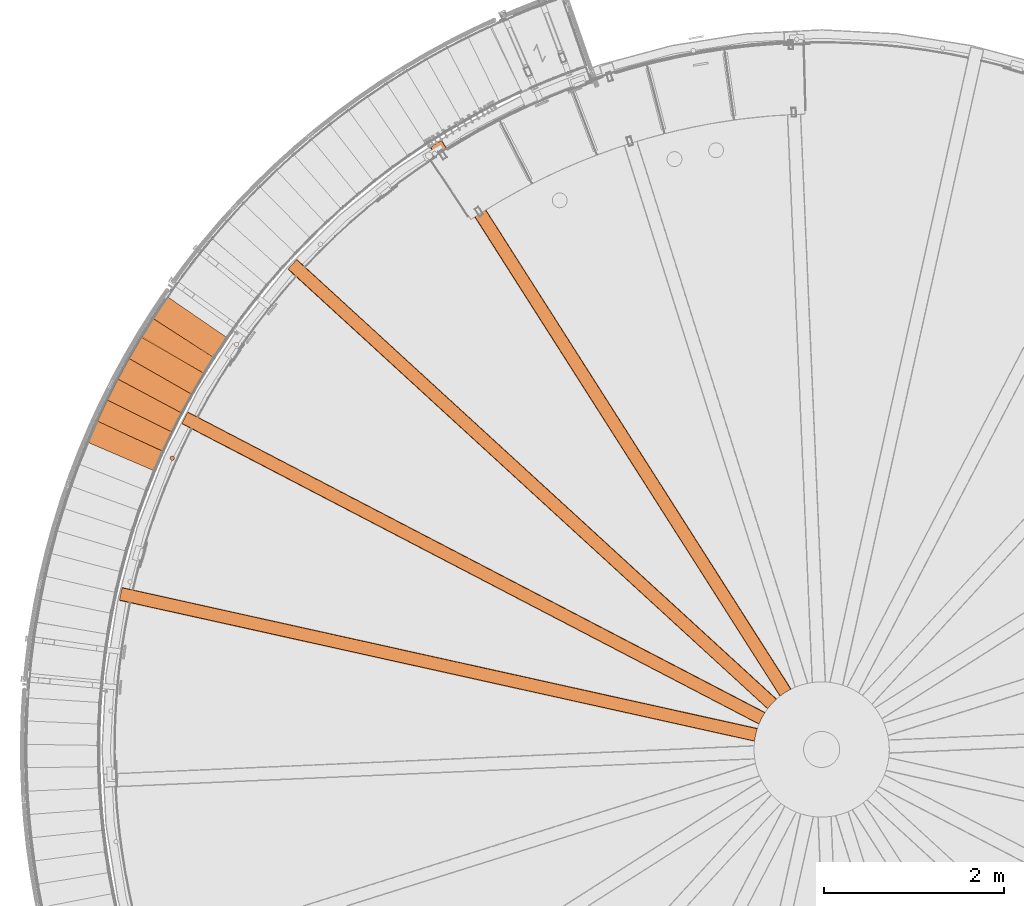
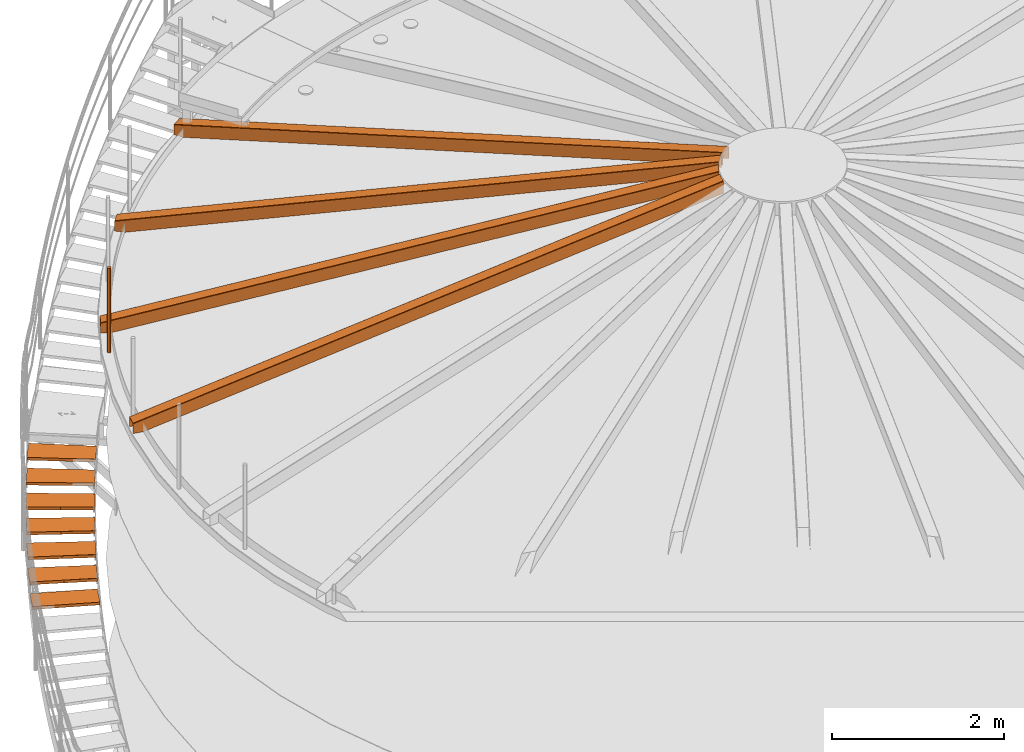
# One storey, part 29 of 126: 16 proxies.
"""IFC2X3 building model written with IfcOpenShell, lengths in millimetres."""

from ifc_helpers import new_model, si_unit, origin, origin_with_axes, place, context, project, spatial, faceted_brep, material, element, save


model = new_model("IFC2X3")

# Units and contexts
context_of_model_1 = context(None, 3, precision=0.1, world=origin())
context_of_model_2 = context(None, 3, precision=0.1, world=origin())
ifc_project = project(units=[si_unit("LENGTHUNIT", "METRE", prefix="MILLI"), si_unit("AREAUNIT", "SQUARE_METRE", prefix="CENTI"), si_unit("VOLUMEUNIT", "CUBIC_METRE", prefix="CENTI"), si_unit("MASSUNIT", "GRAM", prefix="KILO")], contexts=[context_of_model_1, context_of_model_2])

# Site, building, storey
site_placement = place(None, origin_with_axes())
site = spatial("IfcSite", under=ifc_project, at=site_placement, CompositionType="ELEMENT")
building_placement = place(site_placement, origin_with_axes())
building = spatial("IfcBuilding", under=site, at=building_placement, CompositionType="ELEMENT")
storey_placement = place(building_placement, origin_with_axes())
storey = spatial("IfcBuildingStorey", under=building, at=storey_placement, CompositionType="ELEMENT")

# Proxies
ifc_material_1 = material(Name="HOLZ")
proxy_1_placement = place(storey_placement, origin_with_axes())
element("IfcBuildingElementProxy", 1, at=proxy_1_placement, inside=storey, material=ifc_material_1, context=context_of_model_2, shape_type="Brep", body=[
    faceted_brep([(97.3821, 11904.88, 7274.6625), (85.7743, 11881.255, 7274.6625), (74.2371, 11857.595, 7274.6625), (62.7705, 11833.9, 7274.6625), (51.3748, 11810.172, 7274.6625), (40.05, 11786.41, 7274.6625), (28.7961, 11762.613, 7274.6625), (17.6134, 11738.784, 7274.6625), (6.5018, 11714.921, 7274.6625), (-4.5384, 11691.025, 7274.6625), (-15.5073, 11667.096, 7274.6625), (-26.4047, 11643.135, 7274.6625), (702.3153, 11313.033, 7274.6625), (713.3315, 11337.245, 7274.6625), (724.428, 11361.42, 7274.6625), (735.6046, 11385.559, 7274.6625), (746.8612, 11409.66, 7274.6625), (758.1978, 11433.724, 7274.6625), (769.6141, 11457.749, 7274.6625), (781.1101, 11481.737, 7274.6625), (792.6857, 11505.687, 7274.6625), (804.3406, 11529.598, 7274.6625), (816.0748, 11553.47, 7274.6625), (97.3821, 11904.88, 7234.6625), (816.0748, 11553.47, 7234.6625), (804.3406, 11529.598, 7234.6625), (792.6857, 11505.687, 7234.6625), (781.1101, 11481.737, 7234.6625), (769.6141, 11457.749, 7234.6625), (758.1978, 11433.724, 7234.6625), (746.8612, 11409.66, 7234.6625), (735.6046, 11385.559, 7234.6625), (724.428, 11361.42, 7234.6625), (713.3315, 11337.245, 7234.6625), (702.3153, 11313.033, 7234.6625), (-26.4047, 11643.135, 7234.6625), (-15.5073, 11667.096, 7234.6625), (-4.5384, 11691.025, 7234.6625), (6.5018, 11714.921, 7234.6625), (17.6134, 11738.784, 7234.6625), (28.7961, 11762.613, 7234.6625), (40.05, 11786.41, 7234.6625), (51.3748, 11810.172, 7234.6625), (62.7705, 11833.9, 7234.6625), (74.2371, 11857.595, 7234.6625), (85.7743, 11881.255, 7234.6625)], [[[0, 1, 2, 3, 4, 5, 6, 7, 8, 9, 10, 11, 12, 13, 14, 15, 16, 17, 18, 19, 20, 21, 22]], [[23, 24, 25, 26, 27, 28, 29, 30, 31, 32, 33, 34, 35, 36, 37, 38, 39, 40, 41, 42, 43, 44, 45]], [[0, 23, 45, 1]], [[1, 45, 44, 2]], [[2, 44, 43, 3]], [[3, 43, 42, 4]], [[4, 42, 41, 5]], [[5, 41, 40, 6]], [[6, 40, 39, 7]], [[7, 39, 38, 8]], [[8, 38, 37, 9]], [[9, 37, 36, 10]], [[10, 36, 35, 11]], [[11, 35, 34, 12]], [[12, 34, 33, 13]], [[13, 33, 32, 14]], [[14, 32, 31, 15]], [[15, 31, 30, 16]], [[16, 30, 29, 17]], [[17, 29, 28, 18]], [[18, 28, 27, 19]], [[19, 27, 26, 20]], [[20, 26, 25, 21]], [[21, 25, 24, 22]], [[22, 24, 23, 0]]]),
])
proxy_2_placement = place(storey_placement, origin_with_axes())
element("IfcBuildingElementProxy", 2, at=proxy_2_placement, inside=storey, material=ifc_material_1, context=context_of_model_2, shape_type="Brep", body=[
    faceted_brep([(215.5957, 12135.94, 7447.8688), (203.2975, 12112.667, 7447.8688), (191.0689, 12089.357, 7447.8688), (178.91, 12066.01, 7447.8688), (166.8207, 12042.627, 7447.8688), (154.8014, 12019.208, 7447.8688), (142.852, 11995.754, 7447.8688), (130.9727, 11972.264, 7447.8688), (119.1636, 11948.738, 7447.8688), (107.4248, 11925.178, 7447.8688), (95.7564, 11901.582, 7447.8688), (84.1584, 11877.952, 7447.8688), (802.8466, 11526.544, 7447.8688), (814.5707, 11550.422, 7447.8688), (826.3739, 11574.26, 7447.8688), (838.2562, 11598.059, 7447.8688), (850.2173, 11621.818, 7447.8688), (862.2573, 11645.538, 7447.8688), (874.3758, 11669.217, 7447.8688), (886.5729, 11692.856, 7447.8688), (898.8483, 11716.455, 7447.8688), (911.202, 11740.012, 7447.8688), (923.6337, 11763.529, 7447.8688), (215.5957, 12135.94, 7407.8688), (923.6337, 11763.529, 7407.8688), (911.202, 11740.012, 7407.8688), (898.8483, 11716.455, 7407.8688), (886.5729, 11692.856, 7407.8688), (874.3758, 11669.217, 7407.8688), (862.2573, 11645.538, 7407.8688), (850.2173, 11621.818, 7407.8688), (838.2562, 11598.059, 7407.8688), (826.3739, 11574.26, 7407.8688), (814.5707, 11550.422, 7407.8688), (802.8466, 11526.544, 7407.8688), (84.1584, 11877.952, 7407.8688), (95.7564, 11901.582, 7407.8688), (107.4248, 11925.178, 7407.8688), (119.1636, 11948.738, 7407.8688), (130.9727, 11972.264, 7407.8688), (142.852, 11995.754, 7407.8688), (154.8014, 12019.208, 7407.8688), (166.8207, 12042.627, 7407.8688), (178.91, 12066.01, 7407.8688), (191.0689, 12089.357, 7407.8688), (203.2975, 12112.667, 7407.8688)], [[[0, 1, 2, 3, 4, 5, 6, 7, 8, 9, 10, 11, 12, 13, 14, 15, 16, 17, 18, 19, 20, 21, 22]], [[23, 24, 25, 26, 27, 28, 29, 30, 31, 32, 33, 34, 35, 36, 37, 38, 39, 40, 41, 42, 43, 44, 45]], [[0, 23, 45, 1]], [[1, 45, 44, 2]], [[2, 44, 43, 3]], [[3, 43, 42, 4]], [[4, 42, 41, 5]], [[5, 41, 40, 6]], [[6, 40, 39, 7]], [[7, 39, 38, 8]], [[8, 38, 37, 9]], [[9, 37, 36, 10]], [[10, 36, 35, 11]], [[11, 35, 34, 12]], [[12, 34, 33, 13]], [[13, 33, 32, 14]], [[14, 32, 31, 15]], [[15, 31, 30, 16]], [[16, 30, 29, 17]], [[17, 29, 28, 18]], [[18, 28, 27, 19]], [[19, 27, 26, 20]], [[20, 26, 25, 21]], [[21, 25, 24, 22]], [[22, 24, 23, 0]]]),
])
proxy_3_placement = place(storey_placement, origin_with_axes())
element("IfcBuildingElementProxy", 3, at=proxy_3_placement, inside=storey, material=ifc_material_1, context=context_of_model_2, shape_type="Brep", body=[
    faceted_brep([(340.559, 12363.421, 7621.075), (327.5811, 12340.519, 7621.075), (314.6717, 12317.579, 7621.075), (301.8309, 12294.601, 7621.075), (289.0586, 12271.584, 7621.075), (276.3552, 12248.529, 7621.075), (263.7207, 12225.436, 7621.075), (251.1551, 12202.306, 7621.075), (238.6587, 12179.138, 7621.075), (226.2315, 12155.933, 7621.075), (213.8736, 12132.692, 7621.075), (201.5852, 12109.413, 7621.075), (909.6188, 11737.004, 7621.075), (922.0405, 11760.526, 7621.075), (934.5403, 11784.006, 7621.075), (947.1179, 11807.445, 7621.075), (959.7732, 11830.842, 7621.075), (972.5061, 11854.197, 7621.075), (985.3164, 11877.509, 7621.075), (998.2039, 11900.779, 7621.075), (1011.1686, 11924.006, 7621.075), (1024.2103, 11947.19, 7621.075), (1037.3289, 11970.331, 7621.075), (340.559, 12363.421, 7581.075), (1037.3289, 11970.331, 7581.075), (1024.2103, 11947.19, 7581.075), (1011.1686, 11924.006, 7581.075), (998.2039, 11900.779, 7581.075), (985.3164, 11877.509, 7581.075), (972.5061, 11854.197, 7581.075), (959.7732, 11830.842, 7581.075), (947.1179, 11807.445, 7581.075), (934.5403, 11784.006, 7581.075), (922.0405, 11760.526, 7581.075), (909.6188, 11737.004, 7581.075), (201.5852, 12109.413, 7581.075), (213.8736, 12132.692, 7581.075), (226.2315, 12155.933, 7581.075), (238.6587, 12179.138, 7581.075), (251.1551, 12202.306, 7581.075), (263.7207, 12225.436, 7581.075), (276.3552, 12248.529, 7581.075), (289.0586, 12271.584, 7581.075), (301.8309, 12294.601, 7581.075), (314.6717, 12317.579, 7581.075), (327.5811, 12340.519, 7581.075)], [[[0, 1, 2, 3, 4, 5, 6, 7, 8, 9, 10, 11, 12, 13, 14, 15, 16, 17, 18, 19, 20, 21, 22]], [[23, 24, 25, 26, 27, 28, 29, 30, 31, 32, 33, 34, 35, 36, 37, 38, 39, 40, 41, 42, 43, 44, 45]], [[0, 23, 45, 1]], [[1, 45, 44, 2]], [[2, 44, 43, 3]], [[3, 43, 42, 4]], [[4, 42, 41, 5]], [[5, 41, 40, 6]], [[6, 40, 39, 7]], [[7, 39, 38, 8]], [[8, 38, 37, 9]], [[9, 37, 36, 10]], [[10, 36, 35, 11]], [[11, 35, 34, 12]], [[12, 34, 33, 13]], [[13, 33, 32, 14]], [[14, 32, 31, 15]], [[15, 31, 30, 16]], [[16, 30, 29, 17]], [[17, 29, 28, 18]], [[18, 28, 27, 19]], [[19, 27, 26, 20]], [[20, 26, 25, 21]], [[21, 25, 24, 22]], [[22, 24, 23, 0]]]),
])
proxy_4_placement = place(storey_placement, origin_with_axes())
element("IfcBuildingElementProxy", 4, at=proxy_4_placement, inside=storey, material=ifc_material_1, context=context_of_model_2, shape_type="Brep", body=[
    faceted_brep([(472.1637, 12587.125, 7794.2813), (458.5174, 12564.615, 7794.2813), (444.9384, 12542.065, 7794.2813), (431.4267, 12519.474, 7794.2813), (417.9826, 12496.843, 7794.2813), (404.6061, 12474.172, 7794.2813), (391.2973, 12451.461, 7794.2813), (378.0564, 12428.711, 7794.2813), (364.8835, 12405.921, 7794.2813), (351.7787, 12383.092, 7794.2813), (338.742, 12360.224, 7794.2813), (325.7738, 12337.317, 7794.2813), (1022.5392, 11944.23, 7794.2813), (1035.648, 11967.376, 7794.2813), (1048.8334, 11990.478, 7794.2813), (1062.0955, 12013.537, 7794.2813), (1075.434, 12036.551, 7794.2813), (1088.8487, 12059.521, 7794.2813), (1102.3396, 12082.446, 7794.2813), (1115.9065, 12105.327, 7794.2813), (1129.5493, 12128.162, 7794.2813), (1143.2677, 12150.952, 7794.2813), (1157.0617, 12173.696, 7794.2813), (472.1637, 12587.125, 7754.2813), (1157.0617, 12173.696, 7754.2813), (1143.2677, 12150.952, 7754.2813), (1129.5493, 12128.162, 7754.2813), (1115.9065, 12105.327, 7754.2813), (1102.3396, 12082.446, 7754.2813), (1088.8487, 12059.521, 7754.2813), (1075.434, 12036.551, 7754.2813), (1062.0955, 12013.537, 7754.2813), (1048.8334, 11990.478, 7754.2813), (1035.648, 11967.376, 7754.2813), (1022.5392, 11944.23, 7754.2813), (325.7738, 12337.317, 7754.2813), (338.742, 12360.224, 7754.2813), (351.7787, 12383.092, 7754.2813), (364.8835, 12405.921, 7754.2813), (378.0564, 12428.711, 7754.2813), (391.2973, 12451.461, 7754.2813), (404.6061, 12474.172, 7754.2813), (417.9826, 12496.843, 7754.2813), (431.4267, 12519.474, 7754.2813), (444.9384, 12542.065, 7754.2813), (458.5174, 12564.615, 7754.2813)], [[[0, 1, 2, 3, 4, 5, 6, 7, 8, 9, 10, 11, 12, 13, 14, 15, 16, 17, 18, 19, 20, 21, 22]], [[23, 24, 25, 26, 27, 28, 29, 30, 31, 32, 33, 34, 35, 36, 37, 38, 39, 40, 41, 42, 43, 44, 45]], [[0, 23, 45, 1]], [[1, 45, 44, 2]], [[2, 44, 43, 3]], [[3, 43, 42, 4]], [[4, 42, 41, 5]], [[5, 41, 40, 6]], [[6, 40, 39, 7]], [[7, 39, 38, 8]], [[8, 38, 37, 9]], [[9, 37, 36, 10]], [[10, 36, 35, 11]], [[11, 35, 34, 12]], [[12, 34, 33, 13]], [[13, 33, 32, 14]], [[14, 32, 31, 15]], [[15, 31, 30, 16]], [[16, 30, 29, 17]], [[17, 29, 28, 18]], [[18, 28, 27, 19]], [[19, 27, 26, 20]], [[20, 26, 25, 21]], [[21, 25, 24, 22]], [[22, 24, 23, 0]]]),
])
proxy_5_placement = place(storey_placement, origin_with_axes())
element("IfcBuildingElementProxy", 5, at=proxy_5_placement, inside=storey, material=ifc_material_1, context=context_of_model_2, shape_type="Brep", body=[
    faceted_brep([(610.2958, 12806.858, 7967.4875), (595.9929, 12784.76, 7967.4875), (581.756, 12762.619, 7967.4875), (567.5853, 12740.436, 7967.4875), (553.4809, 12718.21, 7967.4875), (539.4429, 12695.943, 7967.4875), (525.4714, 12673.634, 7967.4875), (511.5666, 12651.283, 7967.4875), (497.7286, 12628.891, 7967.4875), (483.9575, 12606.457, 7967.4875), (470.2535, 12583.983, 7967.4875), (456.6166, 12561.467, 7967.4875), (1141.5102, 12148.042, 7967.4875), (1155.2945, 12170.792, 7967.4875), (1169.1543, 12193.496, 7967.4875), (1183.0892, 12216.155, 7967.4875), (1197.0993, 12238.766, 7967.4875), (1211.1844, 12261.332, 7967.4875), (1225.3442, 12283.85, 7967.4875), (1239.5787, 12306.321, 7967.4875), (1253.8877, 12328.745, 7967.4875), (1268.2709, 12351.121, 7967.4875), (1282.7284, 12373.45, 7967.4875), (610.2958, 12806.858, 7927.4875), (1282.7284, 12373.45, 7927.4875), (1268.2709, 12351.121, 7927.4875), (1253.8877, 12328.745, 7927.4875), (1239.5787, 12306.321, 7927.4875), (1225.3442, 12283.85, 7927.4875), (1211.1844, 12261.332, 7927.4875), (1197.0993, 12238.766, 7927.4875), (1183.0892, 12216.155, 7927.4875), (1169.1543, 12193.496, 7927.4875), (1155.2945, 12170.792, 7927.4875), (1141.5102, 12148.042, 7927.4875), (456.6166, 12561.467, 7927.4875), (470.2535, 12583.983, 7927.4875), (483.9575, 12606.457, 7927.4875), (497.7286, 12628.891, 7927.4875), (511.5666, 12651.283, 7927.4875), (525.4714, 12673.634, 7927.4875), (539.4429, 12695.943, 7927.4875), (553.4809, 12718.21, 7927.4875), (567.5853, 12740.436, 7927.4875), (581.756, 12762.619, 7927.4875), (595.9929, 12784.76, 7927.4875)], [[[0, 1, 2, 3, 4, 5, 6, 7, 8, 9, 10, 11, 12, 13, 14, 15, 16, 17, 18, 19, 20, 21, 22]], [[23, 24, 25, 26, 27, 28, 29, 30, 31, 32, 33, 34, 35, 36, 37, 38, 39, 40, 41, 42, 43, 44, 45]], [[0, 23, 45, 1]], [[1, 45, 44, 2]], [[2, 44, 43, 3]], [[3, 43, 42, 4]], [[4, 42, 41, 5]], [[5, 41, 40, 6]], [[6, 40, 39, 7]], [[7, 39, 38, 8]], [[8, 38, 37, 9]], [[9, 37, 36, 10]], [[10, 36, 35, 11]], [[11, 35, 34, 12]], [[12, 34, 33, 13]], [[13, 33, 32, 14]], [[14, 32, 31, 15]], [[15, 31, 30, 16]], [[16, 30, 29, 17]], [[17, 29, 28, 18]], [[18, 28, 27, 19]], [[19, 27, 26, 20]], [[20, 26, 25, 21]], [[21, 25, 24, 22]], [[22, 24, 23, 0]]]),
])
proxy_6_placement = place(storey_placement, origin_with_axes())
element("IfcBuildingElementProxy", 6, at=proxy_6_placement, inside=storey, material=ifc_material_1, context=context_of_model_2, shape_type="Brep", body=[
    faceted_brep([(754.8356, 13022.43, 8140.6938), (739.8885, 13000.763, 8140.6938), (725.0061, 12979.05, 8140.6938), (710.1886, 12957.294, 8140.6938), (695.4361, 12935.493, 8140.6938), (680.7488, 12913.649, 8140.6938), (666.1267, 12891.76, 8140.6938), (651.5701, 12869.829, 8140.6938), (637.079, 12847.853, 8140.6938), (622.6536, 12825.835, 8140.6938), (608.2939, 12803.774, 8140.6938), (594.0002, 12781.669, 8140.6938), (1266.4285, 12348.264, 8140.6938), (1280.8765, 12370.599, 8140.6938), (1295.3985, 12392.885, 8140.6938), (1309.9944, 12415.123, 8140.6938), (1324.6639, 12437.313, 8140.6938), (1339.4071, 12459.454, 8140.6938), (1354.2236, 12481.546, 8140.6938), (1369.1133, 12503.588, 8140.6938), (1384.076, 12525.581, 8140.6938), (1399.1117, 12547.525, 8140.6938), (1414.2201, 12569.418, 8140.6938), (754.8356, 13022.43, 8100.6938), (1414.2201, 12569.418, 8100.6938), (1399.1117, 12547.525, 8100.6938), (1384.076, 12525.581, 8100.6938), (1369.1133, 12503.588, 8100.6938), (1354.2236, 12481.546, 8100.6938), (1339.4071, 12459.454, 8100.6938), (1324.6639, 12437.313, 8100.6938), (1309.9944, 12415.123, 8100.6938), (1295.3985, 12392.885, 8100.6938), (1280.8765, 12370.599, 8100.6938), (1266.4285, 12348.264, 8100.6938), (594.0002, 12781.669, 8100.6938), (608.2939, 12803.774, 8100.6938), (622.6536, 12825.835, 8100.6938), (637.079, 12847.853, 8100.6938), (651.5701, 12869.829, 8100.6938), (666.1267, 12891.76, 8100.6938), (680.7488, 12913.649, 8100.6938), (695.4361, 12935.493, 8100.6938), (710.1886, 12957.294, 8100.6938), (725.0061, 12979.05, 8100.6938), (739.8885, 13000.763, 8100.6938)], [[[0, 1, 2, 3, 4, 5, 6, 7, 8, 9, 10, 11, 12, 13, 14, 15, 16, 17, 18, 19, 20, 21, 22]], [[23, 24, 25, 26, 27, 28, 29, 30, 31, 32, 33, 34, 35, 36, 37, 38, 39, 40, 41, 42, 43, 44, 45]], [[0, 23, 45, 1]], [[1, 45, 44, 2]], [[2, 44, 43, 3]], [[3, 43, 42, 4]], [[4, 42, 41, 5]], [[5, 41, 40, 6]], [[6, 40, 39, 7]], [[7, 39, 38, 8]], [[8, 38, 37, 9]], [[9, 37, 36, 10]], [[10, 36, 35, 11]], [[11, 35, 34, 12]], [[12, 34, 33, 13]], [[13, 33, 32, 14]], [[14, 32, 31, 15]], [[15, 31, 30, 16]], [[16, 30, 29, 17]], [[17, 29, 28, 18]], [[18, 28, 27, 19]], [[19, 27, 26, 20]], [[20, 26, 25, 21]], [[21, 25, 24, 22]], [[22, 24, 23, 0]]]),
])
ifc_material_2 = material(Name="S235JRG2")
proxy_7_placement = place(storey_placement, origin_with_axes())
element("IfcBuildingElementProxy", 7, at=proxy_7_placement, inside=storey, material=ifc_material_2, context=context_of_model_2, shape_type="Brep", body=[
    faceted_brep([(-124.0547, 11406.406, 7061.09), (-124.0547, 11406.406, 7101.09), (-17.7629, 11654.603, 7101.09), (-17.7629, 11654.603, 7061.09), (602.1531, 11095.404, 7061.09), (708.4449, 11343.602, 7061.09), (708.4449, 11343.602, 7101.09), (602.1531, 11095.404, 7101.09)], [[[0, 1, 2, 3]], [[4, 5, 6, 7]], [[0, 4, 7, 1]], [[1, 7, 6, 2]], [[2, 6, 5, 3]], [[3, 5, 4, 0]]]),
])
proxy_8_placement = place(storey_placement, origin_with_axes())
element("IfcBuildingElementProxy", 8, at=proxy_8_placement, inside=storey, material=ifc_material_2, context=context_of_model_2, shape_type="Brep", body=[
    faceted_brep([(-20.4174, 11644.199, 7234.25), (-20.4174, 11644.199, 7274.25), (93.1337, 11889.16, 7274.25), (93.1337, 11889.16, 7234.25), (696.3219, 11311.957, 7234.25), (809.873, 11556.918, 7234.25), (809.873, 11556.918, 7274.25), (696.3219, 11311.957, 7274.25)], [[[0, 1, 2, 3]], [[4, 5, 6, 7]], [[0, 4, 7, 1]], [[1, 7, 6, 2]], [[2, 6, 5, 3]], [[3, 5, 4, 0]]]),
])
proxy_9_placement = place(storey_placement, origin_with_axes())
element("IfcBuildingElementProxy", 9, at=proxy_9_placement, inside=storey, material=ifc_material_2, context=context_of_model_2, shape_type="Brep", body=[
    faceted_brep([(90.1741, 11878.839, 7407.41), (90.1741, 11878.839, 7447.41), (210.8861, 12120.352, 7447.41), (210.8861, 12120.352, 7407.41), (796.8238, 11525.644, 7407.41), (917.5358, 11767.157, 7407.41), (917.5358, 11767.157, 7447.41), (796.8238, 11525.644, 7447.41)], [[[0, 1, 2, 3]], [[4, 5, 6, 7]], [[0, 4, 7, 1]], [[1, 7, 6, 2]], [[2, 6, 5, 3]], [[3, 5, 4, 0]]]),
])
proxy_10_placement = place(storey_placement, origin_with_axes())
element("IfcBuildingElementProxy", 10, at=proxy_10_placement, inside=storey, material=ifc_material_2, context=context_of_model_2, shape_type="Brep", body=[
    faceted_brep([(207.624, 12110.121, 7580.57), (207.624, 12110.121, 7620.57), (335.3923, 12347.977, 7620.57), (335.3923, 12347.977, 7580.57), (903.5718, 11736.281, 7580.57), (1031.34, 11974.136, 7580.57), (1031.34, 11974.136, 7620.57), (903.5718, 11736.281, 7620.57)], [[[0, 1, 2, 3]], [[4, 5, 6, 7]], [[0, 4, 7, 1]], [[1, 7, 6, 2]], [[2, 6, 5, 3]], [[3, 5, 4, 0]]]),
])
proxy_11_placement = place(storey_placement, origin_with_axes())
element("IfcBuildingElementProxy", 11, at=proxy_11_placement, inside=storey, material=ifc_material_2, context=context_of_model_2, shape_type="Brep", body=[
    faceted_brep([(331.8305, 12337.847, 7753.73), (331.8305, 12337.847, 7793.73), (466.5443, 12571.839, 7793.73), (466.5443, 12571.839, 7753.73), (1016.4733, 11943.684, 7753.73), (1151.1871, 12177.676, 7753.73), (1151.1871, 12177.676, 7793.73), (1016.4733, 11943.684, 7793.73)], [[[0, 1, 2, 3]], [[4, 5, 6, 7]], [[0, 4, 7, 1]], [[1, 7, 6, 2]], [[2, 6, 5, 3]], [[3, 5, 4, 0]]]),
])
ifc_material_3 = material(Name="STAHL")
proxy_12_placement = place(storey_placement, origin_with_axes())
element("IfcBuildingElementProxy", 12, at=proxy_12_placement, inside=storey, material=ifc_material_3, Name="profile", context=context_of_model_2, shape_type="Brep", body=[
    faceted_brep([(828.4, 11242.3, 11706.0), (828.4, 11242.3, 10506.0), (825.7, 11247.5, 10506.0), (825.7, 11247.5, 11706.0), (821.8, 11251.8, 10506.0), (821.8, 11251.8, 11706.0), (817.0, 11255.1, 10506.0), (817.0, 11255.1, 11706.0), (811.5, 11257.1, 10506.0), (811.5, 11257.1, 11706.0), (805.7, 11257.8, 10506.0), (805.7, 11257.8, 11706.0), (799.9, 11257.1, 10506.0), (799.9, 11257.1, 11706.0), (794.5, 11255.0, 10506.0), (794.5, 11255.0, 11706.0), (789.7, 11251.7, 10506.0), (789.7, 11251.7, 11706.0), (785.9, 11247.3, 10506.0), (785.9, 11247.3, 11706.0), (783.2, 11242.1, 10506.0), (783.2, 11242.1, 11706.0), (781.9, 11236.5, 10506.0), (781.9, 11236.5, 11706.0), (781.9, 11230.6, 10506.0), (781.9, 11230.6, 11706.0), (783.3, 11225.0, 11706.0), (783.3, 11225.0, 10506.0), (786.0, 11219.8, 10506.0), (786.0, 11219.8, 11706.0), (789.9, 11215.5, 10506.0), (789.9, 11215.5, 11706.0), (794.7, 11212.2, 10506.0), (794.7, 11212.2, 11706.0), (800.2, 11210.2, 10506.0), (800.2, 11210.2, 11706.0), (806.0, 11209.5, 10506.0), (806.0, 11209.5, 11706.0), (811.7, 11210.3, 10506.0), (811.7, 11210.3, 11706.0), (817.2, 11212.3, 10506.0), (817.2, 11212.3, 11706.0), (822.0, 11215.7, 10506.0), (822.0, 11215.7, 11706.0), (825.8, 11220.1, 10506.0), (825.8, 11220.1, 11706.0), (828.5, 11225.2, 10506.0), (828.5, 11225.2, 11706.0), (829.8, 11230.9, 10506.0), (829.8, 11230.9, 11706.0), (829.8, 11236.7, 10506.0), (829.8, 11236.7, 11706.0)], [[[0, 1, 2, 3]], [[3, 2, 4, 5]], [[5, 4, 6, 7]], [[7, 6, 8, 9]], [[9, 8, 10, 11]], [[11, 10, 12, 13]], [[13, 12, 14, 15]], [[15, 14, 16, 17]], [[17, 16, 18, 19]], [[19, 18, 20, 21]], [[21, 20, 22, 23]], [[23, 22, 24, 25]], [[26, 25, 24, 27]], [[26, 27, 28, 29]], [[29, 28, 30, 31]], [[31, 30, 32, 33]], [[33, 32, 34, 35]], [[35, 34, 36, 37]], [[37, 36, 38, 39]], [[39, 38, 40, 41]], [[41, 40, 42, 43]], [[43, 42, 44, 45]], [[45, 44, 46, 47]], [[47, 46, 48, 49]], [[49, 48, 50, 51]], [[51, 50, 1, 0]], [[37, 39, 41, 43, 45, 47, 49, 51, 0, 3, 5, 7, 9, 11, 13, 15, 17, 19, 21, 23, 25, 26, 29, 31, 33, 35]], [[36, 34, 32, 30, 28, 27, 24, 22, 20, 18, 16, 14, 12, 10, 8, 6, 4, 2, 1, 50, 48, 46, 44, 42, 40, 38]]]),
])
proxy_13_placement = place(storey_placement, origin_with_axes())
element("IfcBuildingElementProxy", 13, at=proxy_13_placement, inside=storey, material=ifc_material_3, Name="profile", context=context_of_model_2, shape_type="Brep", body=[
    faceted_brep([(7541.6, 8594.7, 12406.2), (7544.7, 8597.2, 12406.1), (7544.7, 8597.2, 12573.8), (7544.8, 8597.2, 12574.5), (7544.9, 8597.3, 12575.2), (7545.2, 8597.5, 12576.0), (7545.6, 8597.8, 12576.6), (7546.0, 8598.1, 12577.1), (7546.5, 8598.6, 12577.5), (7547.2, 8599.1, 12577.8), (7547.9, 8599.6, 12577.9), (7602.0, 8637.5, 12577.1), (7661.0, 8671.5, 12577.9), (7661.4, 8671.7, 12577.9), (7661.8, 8671.9, 12577.8), (7662.6, 8672.3, 12577.6), (7663.2, 8672.6, 12577.1), (7663.8, 8672.9, 12576.5), (7664.2, 8673.1, 12575.8), (7664.5, 8673.2, 12574.9), (7664.6, 8673.3, 12573.9), (7664.6, 8673.3, 12406.2), (7668.2, 8675.1, 12406.3), (7668.2, 8675.1, 12574.0), (7668.1, 8675.1, 12575.4), (7667.8, 8674.9, 12576.8), (7667.2, 8674.6, 12578.2), (7666.3, 8674.2, 12579.5), (7665.4, 8673.7, 12580.5), (7664.2, 8673.1, 12581.3), (7662.7, 8672.3, 12581.9), (7661.0, 8671.5, 12582.1), (7602.0, 8637.5, 12581.2), (7547.9, 8599.6, 12582.0), (7547.2, 8599.1, 12582.0), (7546.5, 8598.5, 12581.8), (7545.2, 8597.5, 12581.3), (7544.0, 8596.6, 12580.4), (7543.1, 8595.9, 12579.2), (7542.3, 8595.3, 12577.8), (7541.8, 8594.9, 12576.0), (7541.6, 8594.7, 12573.9), (3665.7, 14678.6, 10506.0), (3665.7, 14678.6, 10641.0), (3665.8, 14678.7, 10642.6), (3666.2, 14679.0, 10644.2), (3667.0, 14679.5, 10645.9), (3668.0, 14680.1, 10647.3), (3669.4, 14681.0, 10648.4), (3670.9, 14681.9, 10649.1), (3672.4, 14682.9, 10649.3), (3785.4, 14754.9, 10649.3), (3786.8, 14755.8, 10649.2), (3788.0, 14756.6, 10648.7), (3789.4, 14757.5, 10647.7), (3790.6, 14758.2, 10646.4), (3791.5, 14758.8, 10644.8), (3792.0, 14759.1, 10643.0), (3792.2, 14759.2, 10641.0), (3792.2, 14759.2, 10506.0), (3788.8, 14757.1, 10506.0), (3788.8, 14757.1, 10641.0), (3788.8, 14757.0, 10641.8), (3788.6, 14756.9, 10642.6), (3788.2, 14756.7, 10643.5), (3787.6, 14756.3, 10644.2), (3787.0, 14755.9, 10644.7), (3786.2, 14755.4, 10645.1), (3785.4, 14754.9, 10645.2), (3672.4, 14682.9, 10645.2), (3671.8, 14682.5, 10645.1), (3671.1, 14682.1, 10644.9), (3670.4, 14681.7, 10644.4), (3669.9, 14681.3, 10643.7), (3669.4, 14681.0, 10642.9), (3669.2, 14680.8, 10642.0), (3669.1, 14680.8, 10641.0), (3669.1, 14680.8, 10506.0), (3854.4, 14654.2, 10506.0), (3857.7, 14656.4, 10506.0), (3731.2, 14575.8, 10506.0), (3734.6, 14577.9, 10506.0)], [[[0, 1, 2, 3, 4, 5, 6, 7, 8, 9, 10, 11, 12, 13, 14, 15, 16, 17, 18, 19, 20, 21, 22, 23, 24, 25, 26, 27, 28, 29, 30, 31, 32, 33, 34, 35, 36, 37, 38, 39, 40, 41]], [[42, 43, 44, 45, 46, 47, 48, 49, 50, 51, 52, 53, 54, 55, 56, 57, 58, 59, 60, 61, 62, 63, 64, 65, 66, 67, 68, 69, 70, 71, 72, 73, 74, 75, 76, 77]], [[21, 78, 79, 22]], [[24, 23, 22, 79, 59, 58, 57]], [[26, 25, 24, 57, 56]], [[26, 56, 55, 27]], [[27, 55, 54, 28]], [[29, 28, 54, 53]], [[30, 29, 53, 52]], [[35, 34, 33, 32, 31, 30, 52, 51, 50, 49]], [[36, 35, 49, 48]], [[37, 36, 48, 47]], [[38, 37, 47, 46]], [[39, 38, 46, 45]], [[40, 39, 45, 44]], [[0, 41, 40, 44, 43, 42, 80]], [[1, 0, 80, 81]], [[77, 81, 80, 42]], [[60, 59, 79, 78]], [[19, 62, 61, 60, 78, 21, 20]], [[19, 18, 63, 62]], [[18, 17, 64, 63]], [[17, 16, 65, 64]], [[16, 15, 66, 65]], [[15, 14, 67, 66]], [[9, 70, 69, 68, 67, 14, 13, 12, 11, 10]], [[9, 8, 71, 70]], [[8, 7, 72, 71]], [[6, 73, 72, 7]], [[5, 74, 73, 6]], [[3, 75, 74, 5, 4]], [[2, 1, 81, 77, 76, 75, 3]]]),
])
proxy_14_placement = place(storey_placement, origin_with_axes())
element("IfcBuildingElementProxy", 14, at=proxy_14_placement, inside=storey, material=ifc_material_3, Name="profile", context=context_of_model_2, shape_type="Brep", body=[
    faceted_brep([(7404.7, 8454.7, 12573.9), (7404.7, 8454.7, 12406.2), (7407.2, 8457.9, 12406.1), (7407.2, 8457.9, 12573.8), (7407.2, 8457.9, 12574.5), (7407.3, 8458.1, 12575.2), (7407.5, 8458.3, 12576.0), (7407.8, 8458.7, 12576.6), (7408.1, 8459.1, 12577.1), (7408.5, 8459.7, 12577.5), (7409.0, 8460.3, 12577.8), (7409.6, 8461.1, 12577.9), (7452.0, 8511.7, 12577.1), (7500.3, 8559.7, 12577.9), (7500.6, 8560.0, 12577.9), (7500.9, 8560.3, 12577.8), (7501.5, 8560.9, 12577.6), (7502.1, 8561.4, 12577.1), (7502.5, 8561.8, 12576.5), (7502.9, 8562.1, 12575.8), (7503.1, 8562.3, 12574.9), (7503.2, 8562.4, 12573.9), (7503.2, 8562.4, 12406.2), (7506.2, 8565.1, 12406.3), (7506.2, 8565.1, 12574.0), (7506.1, 8565.0, 12575.4), (7505.9, 8564.8, 12576.8), (7505.4, 8564.3, 12578.2), (7504.7, 8563.7, 12579.5), (7503.9, 8563.0, 12580.5), (7502.9, 8562.1, 12581.3), (7501.6, 8561.0, 12581.9), (7500.3, 8559.7, 12582.1), (7452.0, 8511.7, 12581.2), (7409.6, 8461.1, 12582.0), (7409.1, 8460.4, 12582.0), (7408.5, 8459.6, 12581.8), (7407.5, 8458.3, 12581.3), (7406.6, 8457.2, 12580.4), (7405.9, 8456.2, 12579.2), (7405.3, 8455.4, 12577.8), (7404.9, 8454.9, 12576.0), (2086.3, 13328.1, 10506.0), (2086.3, 13328.1, 10641.0), (2086.4, 13328.3, 10642.6), (2086.7, 13328.6, 10644.2), (2087.3, 13329.3, 10645.9), (2088.2, 13330.2, 10647.3), (2089.2, 13331.4, 10648.4), (2090.4, 13332.7, 10649.1), (2091.7, 13334.0, 10649.3), (2182.2, 13432.8, 10649.3), (2183.3, 13434.0, 10649.2), (2184.3, 13435.1, 10648.7), (2185.4, 13436.3, 10647.7), (2186.3, 13437.3, 10646.4), (2187.0, 13438.1, 10644.8), (2187.5, 13438.6, 10643.0), (2187.6, 13438.7, 10641.0), (2187.6, 13438.7, 10506.0), (2184.9, 13435.8, 10506.0), (2184.9, 13435.8, 10641.0), (2184.9, 13435.7, 10641.8), (2184.7, 13435.6, 10642.6), (2184.4, 13435.2, 10643.5), (2184.0, 13434.7, 10644.2), (2183.4, 13434.2, 10644.7), (2182.8, 13433.5, 10645.1), (2182.2, 13432.8, 10645.2), (2091.7, 13334.0, 10645.2), (2091.2, 13333.5, 10645.1), (2090.6, 13332.9, 10644.9), (2090.1, 13332.3, 10644.4), (2089.6, 13331.8, 10643.7), (2089.3, 13331.4, 10642.9), (2089.1, 13331.2, 10642.0), (2089.0, 13331.1, 10641.0), (2089.0, 13331.1, 10506.0), (2274.8, 13353.4, 10506.0), (2277.5, 13356.3, 10506.0), (2176.2, 13245.7, 10506.0), (2178.9, 13248.7, 10506.0)], [[[0, 1, 2, 3, 4, 5, 6, 7, 8, 9, 10, 11, 12, 13, 14, 15, 16, 17, 18, 19, 20, 21, 22, 23, 24, 25, 26, 27, 28, 29, 30, 31, 32, 33, 34, 35, 36, 37, 38, 39, 40, 41]], [[42, 43, 44, 45, 46, 47, 48, 49, 50, 51, 52, 53, 54, 55, 56, 57, 58, 59, 60, 61, 62, 63, 64, 65, 66, 67, 68, 69, 70, 71, 72, 73, 74, 75, 76, 77]], [[22, 78, 79, 23]], [[25, 24, 23, 79, 59, 58, 57]], [[28, 27, 26, 25, 57, 56, 55]], [[28, 55, 54, 29]], [[30, 29, 54, 53]], [[31, 30, 53, 52]], [[36, 35, 34, 33, 32, 31, 52, 51, 50, 49]], [[37, 36, 49, 48]], [[38, 37, 48, 47]], [[39, 38, 47, 46]], [[41, 40, 39, 46, 45, 44]], [[0, 41, 44, 43, 42, 80, 1]], [[2, 1, 80, 81]], [[77, 81, 80, 42]], [[60, 59, 79, 78]], [[20, 62, 61, 60, 78, 22, 21]], [[18, 64, 63, 62, 20, 19]], [[18, 17, 65, 64]], [[17, 16, 66, 65]], [[16, 15, 67, 66]], [[10, 70, 69, 68, 67, 15, 14, 13, 12, 11]], [[10, 9, 71, 70]], [[9, 8, 72, 71]], [[7, 73, 72, 8]], [[4, 75, 74, 73, 7, 6, 5]], [[3, 2, 81, 77, 76, 75, 4]]]),
])
proxy_15_placement = place(storey_placement, origin_with_axes())
element("IfcBuildingElementProxy", 15, at=proxy_15_placement, inside=storey, material=ifc_material_3, Name="profile", context=context_of_model_2, shape_type="Brep", body=[
    faceted_brep([(7308.8, 8284.0, 12573.9), (7308.8, 8284.0, 12406.2), (7310.3, 8287.7, 12406.1), (7310.3, 8287.7, 12573.8), (7310.3, 8287.8, 12574.5), (7310.4, 8287.9, 12575.2), (7310.5, 8288.2, 12576.0), (7310.7, 8288.7, 12576.6), (7310.9, 8289.2, 12577.1), (7311.2, 8289.8, 12577.5), (7311.5, 8290.6, 12577.8), (7311.8, 8291.4, 12577.9), (7339.7, 8351.3, 12577.1), (7373.9, 8410.2, 12577.9), (7374.1, 8410.6, 12577.9), (7374.4, 8411.0, 12577.8), (7374.8, 8411.6, 12577.6), (7375.2, 8412.3, 12577.1), (7375.5, 8412.8, 12576.5), (7375.8, 8413.2, 12575.8), (7376.0, 8413.5, 12574.9), (7376.1, 8413.6, 12573.9), (7376.1, 8413.6, 12406.2), (7378.3, 8416.9, 12406.3), (7378.3, 8416.9, 12574.0), (7378.2, 8416.8, 12575.4), (7378.0, 8416.5, 12576.8), (7377.6, 8416.0, 12578.2), (7377.1, 8415.2, 12579.5), (7376.5, 8414.3, 12580.5), (7375.8, 8413.2, 12581.3), (7374.9, 8411.8, 12581.9), (7373.9, 8410.2, 12582.1), (7339.7, 8351.3, 12581.2), (7311.8, 8291.4, 12582.0), (7311.5, 8290.6, 12582.0), (7311.2, 8289.8, 12581.8), (7310.5, 8288.2, 12581.3), (7310.0, 8286.9, 12580.4), (7309.5, 8285.8, 12579.2), (7309.2, 8284.9, 12577.8), (7308.9, 8284.2, 12576.0), (910.2, 11614.9, 10506.0), (910.2, 11614.9, 10641.0), (910.3, 11615.0, 10642.6), (910.5, 11615.4, 10644.2), (910.9, 11616.2, 10645.9), (911.5, 11617.4, 10647.3), (912.2, 11618.8, 10648.4), (913.1, 11620.3, 10649.1), (913.9, 11622.0, 10649.3), (975.8, 11740.8, 10649.3), (976.5, 11742.2, 10649.2), (977.2, 11743.6, 10648.7), (978.0, 11745.0, 10647.7), (978.6, 11746.2, 10646.4), (979.1, 11747.2, 10644.8), (979.4, 11747.7, 10643.0), (979.5, 11747.9, 10641.0), (979.5, 11747.9, 10506.0), (977.6, 11744.4, 10506.0), (977.6, 11744.4, 10641.0), (977.6, 11744.3, 10641.8), (977.5, 11744.1, 10642.6), (977.3, 11743.7, 10643.5), (977.0, 11743.1, 10644.2), (976.6, 11742.4, 10644.7), (976.2, 11741.7, 10645.1), (975.8, 11740.8, 10645.2), (913.9, 11622.0, 10645.2), (913.6, 11621.3, 10645.1), (913.2, 11620.6, 10644.9), (912.8, 11619.9, 10644.4), (912.5, 11619.3, 10643.7), (912.3, 11618.8, 10642.9), (912.1, 11618.5, 10642.0), (912.1, 11618.4, 10641.0), (912.1, 11618.4, 10506.0), (1085.8, 11688.1, 10506.0), (1087.7, 11691.6, 10506.0), (1018.4, 11558.6, 10506.0), (1020.3, 11562.1, 10506.0)], [[[0, 1, 2, 3, 4, 5, 6, 7, 8, 9, 10, 11, 12, 13, 14, 15, 16, 17, 18, 19, 20, 21, 22, 23, 24, 25, 26, 27, 28, 29, 30, 31, 32, 33, 34, 35, 36, 37, 38, 39, 40, 41]], [[42, 43, 44, 45, 46, 47, 48, 49, 50, 51, 52, 53, 54, 55, 56, 57, 58, 59, 60, 61, 62, 63, 64, 65, 66, 67, 68, 69, 70, 71, 72, 73, 74, 75, 76, 77]], [[22, 78, 79, 23]], [[25, 24, 23, 79, 59, 58, 57]], [[27, 26, 25, 57, 56]], [[27, 56, 55, 28]], [[28, 55, 54, 29]], [[30, 29, 54, 53]], [[31, 30, 53, 52]], [[36, 35, 34, 33, 32, 31, 52, 51, 50, 49]], [[37, 36, 49, 48]], [[38, 37, 48, 47]], [[39, 38, 47, 46]], [[40, 39, 46, 45]], [[41, 40, 45, 44]], [[0, 41, 44, 43, 42, 80, 1]], [[2, 1, 80, 81]], [[77, 81, 80, 42]], [[60, 59, 79, 78]], [[20, 62, 61, 60, 78, 22, 21]], [[20, 19, 63, 62]], [[19, 18, 64, 63]], [[18, 17, 65, 64]], [[17, 16, 66, 65]], [[16, 15, 67, 66]], [[10, 70, 69, 68, 67, 15, 14, 13, 12, 11]], [[10, 9, 71, 70]], [[9, 8, 72, 71]], [[7, 73, 72, 8]], [[6, 74, 73, 7]], [[4, 75, 74, 6, 5]], [[3, 2, 81, 77, 76, 75, 4]]]),
])
proxy_16_placement = place(storey_placement, origin_with_axes())
element("IfcBuildingElementProxy", 16, at=proxy_16_placement, inside=storey, material=ifc_material_3, Name="profile", context=context_of_model_2, shape_type="Brep", body=[
    faceted_brep([(7260.3, 8094.3, 12406.2), (7260.8, 8098.3, 12406.1), (7260.8, 8098.3, 12573.8), (7260.8, 8098.3, 12574.5), (7260.9, 8098.5, 12575.2), (7260.9, 8098.9, 12576.0), (7261.0, 8099.3, 12576.6), (7261.0, 8099.9, 12577.1), (7261.1, 8100.5, 12577.5), (7261.2, 8101.3, 12577.8), (7261.3, 8102.3, 12577.9), (7272.8, 8167.3, 12577.1), (7290.5, 8233.0, 12577.9), (7290.6, 8233.5, 12577.9), (7290.8, 8233.9, 12577.8), (7291.0, 8234.7, 12577.6), (7291.3, 8235.4, 12577.1), (7291.4, 8236.0, 12576.5), (7291.6, 8236.4, 12575.8), (7291.7, 8236.7, 12574.9), (7291.7, 8236.9, 12573.9), (7291.7, 8236.9, 12406.2), (7293.0, 8240.7, 12406.3), (7293.0, 8240.7, 12574.0), (7293.0, 8240.6, 12575.4), (7292.8, 8240.2, 12576.8), (7292.6, 8239.6, 12578.2), (7292.3, 8238.7, 12579.5), (7292.0, 8237.7, 12580.5), (7291.6, 8236.4, 12581.3), (7291.1, 8234.8, 12581.9), (7290.5, 8233.0, 12582.1), (7272.8, 8167.3, 12581.2), (7261.3, 8102.3, 12582.0), (7261.2, 8101.4, 12582.0), (7261.1, 8100.5, 12581.8), (7260.9, 8098.9, 12581.3), (7260.7, 8097.4, 12580.4), (7260.6, 8096.2, 12579.2), (7260.4, 8095.2, 12577.8), (7260.4, 8094.5, 12576.0), (7260.3, 8094.3, 12573.9), (217.7, 9655.6, 10506.0), (217.7, 9655.6, 10641.0), (217.7, 9655.8, 10642.6), (217.8, 9656.2, 10644.2), (218.0, 9657.1, 10645.9), (218.3, 9658.4, 10647.3), (218.6, 9659.9, 10648.4), (219.0, 9661.6, 10649.1), (219.4, 9663.4, 10649.3), (248.4, 9794.2, 10649.3), (248.7, 9795.8, 10649.2), (249.1, 9797.2, 10648.7), (249.4, 9798.8, 10647.7), (249.7, 9800.2, 10646.4), (249.9, 9801.2, 10644.8), (250.1, 9801.8, 10643.0), (250.1, 9802.1, 10641.0), (250.1, 9802.1, 10506.0), (249.3, 9798.2, 10506.0), (249.3, 9798.2, 10641.0), (249.3, 9798.1, 10641.8), (249.2, 9797.9, 10642.6), (249.1, 9797.4, 10643.5), (249.0, 9796.8, 10644.2), (248.8, 9796.0, 10644.7), (248.6, 9795.2, 10645.1), (248.4, 9794.2, 10645.2), (219.4, 9663.4, 10645.2), (219.2, 9662.7, 10645.1), (219.1, 9661.9, 10644.9), (218.9, 9661.1, 10644.4), (218.7, 9660.5, 10643.7), (218.6, 9659.9, 10642.9), (218.6, 9659.6, 10642.0), (218.5, 9659.5, 10641.0), (218.5, 9659.5, 10506.0), (368.4, 9771.8, 10506.0), (369.2, 9775.7, 10506.0), (336.8, 9629.2, 10506.0), (337.6, 9633.1, 10506.0)], [[[0, 1, 2, 3, 4, 5, 6, 7, 8, 9, 10, 11, 12, 13, 14, 15, 16, 17, 18, 19, 20, 21, 22, 23, 24, 25, 26, 27, 28, 29, 30, 31, 32, 33, 34, 35, 36, 37, 38, 39, 40, 41]], [[42, 43, 44, 45, 46, 47, 48, 49, 50, 51, 52, 53, 54, 55, 56, 57, 58, 59, 60, 61, 62, 63, 64, 65, 66, 67, 68, 69, 70, 71, 72, 73, 74, 75, 76, 77]], [[21, 78, 79, 22]], [[24, 23, 22, 79, 59, 58, 57]], [[26, 25, 24, 57, 56]], [[26, 56, 55, 27]], [[27, 55, 54, 28]], [[29, 28, 54, 53]], [[30, 29, 53, 52]], [[35, 34, 33, 32, 31, 30, 52, 51, 50, 49]], [[36, 35, 49, 48]], [[37, 36, 48, 47]], [[38, 37, 47, 46]], [[39, 38, 46, 45]], [[40, 39, 45, 44]], [[0, 41, 40, 44, 43, 42, 80]], [[1, 0, 80, 81]], [[77, 81, 80, 42]], [[60, 59, 79, 78]], [[19, 62, 61, 60, 78, 21, 20]], [[19, 18, 63, 62]], [[18, 17, 64, 63]], [[17, 16, 65, 64]], [[16, 15, 66, 65]], [[15, 14, 67, 66]], [[9, 70, 69, 68, 67, 14, 13, 12, 11, 10]], [[9, 8, 71, 70]], [[8, 7, 72, 71]], [[6, 73, 72, 7]], [[5, 74, 73, 6]], [[3, 75, 74, 5, 4]], [[2, 1, 81, 77, 76, 75, 3]]]),
])

save(model, "model.ifc")
